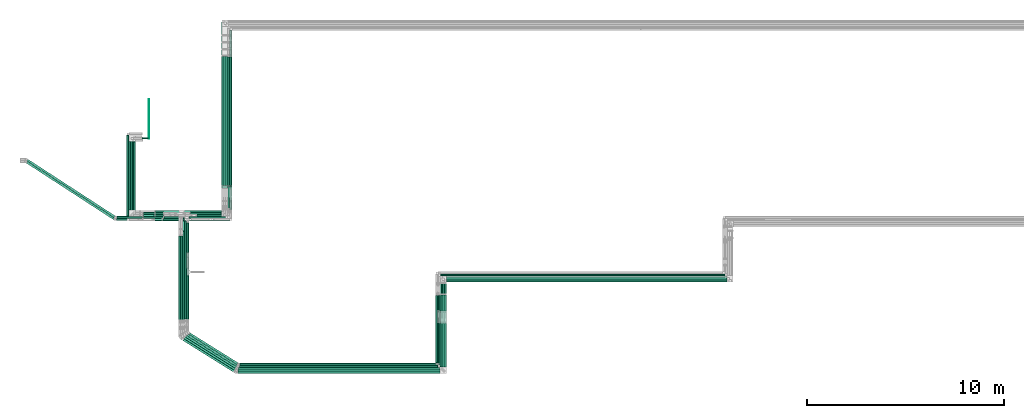
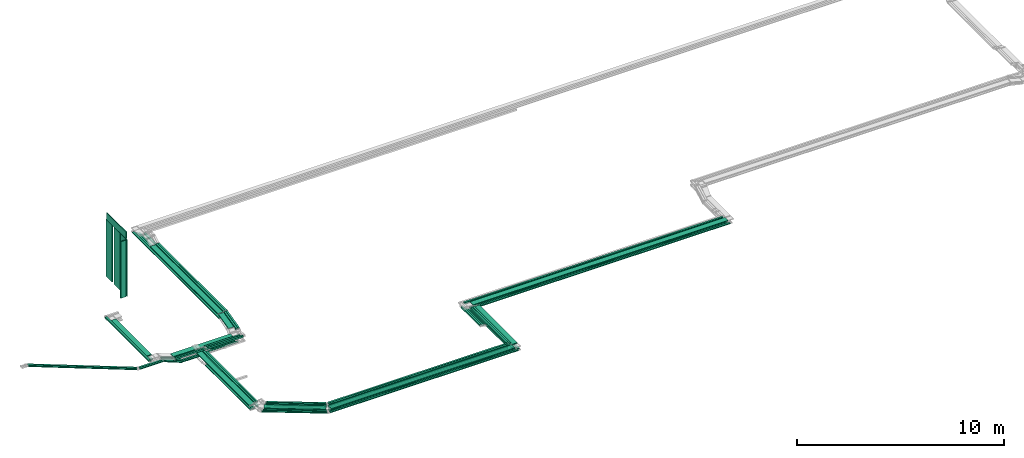
# One storey, part 1 of 14: 73 flow segments.
"""IFC2X3 building model written with IfcOpenShell, lengths in millimetres."""

from ifc_helpers import new_model, entity, si_unit, converted_unit, derived_unit, direction, frame, frame_2d, origin, origin_2d_with_axis, place, context, subcontext, project, spatial, rectangle, extrude, type_object, element, save


model = new_model("IFC2X3")

# Units and contexts
model_context = context("Model", 3, precision=0.01, world=origin(), true_north=direction((6.12303176911189e-17, 1.0)))
body_context = subcontext(model_context, "Body", "Model", "MODEL_VIEW")
ifc_project = project(units=[si_unit("LENGTHUNIT", "METRE", prefix="MILLI"), si_unit("AREAUNIT", "SQUARE_METRE"), si_unit("VOLUMEUNIT", "CUBIC_METRE"), converted_unit("PLANEANGLEUNIT", "DEGREE", entity("IfcRatioMeasure", 0.0174532925199433), si_unit("PLANEANGLEUNIT", "RADIAN"), dimensions=[0, 0, 0, 0, 0, 0, 0]), si_unit("MASSUNIT", "GRAM", prefix="KILO"), derived_unit("MASSDENSITYUNIT", [(si_unit("MASSUNIT", "GRAM", prefix="KILO"), 1), (si_unit("LENGTHUNIT", "METRE"), -3)]), derived_unit("MOMENTOFINERTIAUNIT", [(si_unit("LENGTHUNIT", "METRE"), 4)]), si_unit("TIMEUNIT", "SECOND"), si_unit("FREQUENCYUNIT", "HERTZ"), si_unit("THERMODYNAMICTEMPERATUREUNIT", "DEGREE_CELSIUS"), derived_unit("THERMALTRANSMITTANCEUNIT", [(si_unit("MASSUNIT", "GRAM", prefix="KILO"), 1), (si_unit("THERMODYNAMICTEMPERATUREUNIT", "KELVIN"), -1), (si_unit("TIMEUNIT", "SECOND"), -3)]), derived_unit("VOLUMETRICFLOWRATEUNIT", [(si_unit("LENGTHUNIT", "METRE"), 3), (si_unit("TIMEUNIT", "SECOND"), -1)]), derived_unit("MASSFLOWRATEUNIT", [(si_unit("MASSUNIT", "GRAM", prefix="KILO"), 1), (si_unit("TIMEUNIT", "SECOND"), -1)]), derived_unit("ROTATIONALFREQUENCYUNIT", [(si_unit("TIMEUNIT", "SECOND"), -1)]), si_unit("ELECTRICCURRENTUNIT", "AMPERE"), si_unit("ELECTRICVOLTAGEUNIT", "VOLT"), si_unit("POWERUNIT", "WATT"), si_unit("FORCEUNIT", "NEWTON", prefix="KILO"), si_unit("ILLUMINANCEUNIT", "LUX"), si_unit("LUMINOUSFLUXUNIT", "LUMEN"), si_unit("LUMINOUSINTENSITYUNIT", "CANDELA"), derived_unit("USERDEFINED", [(si_unit("MASSUNIT", "GRAM", prefix="KILO"), -1), (si_unit("LENGTHUNIT", "METRE"), -2), (si_unit("TIMEUNIT", "SECOND"), 3), (si_unit("LUMINOUSFLUXUNIT", "LUMEN"), 1)]), derived_unit("LINEARVELOCITYUNIT", [(si_unit("LENGTHUNIT", "METRE"), 1), (si_unit("TIMEUNIT", "SECOND"), -1)]), si_unit("PRESSUREUNIT", "PASCAL"), derived_unit("USERDEFINED", [(si_unit("LENGTHUNIT", "METRE"), -2), (si_unit("MASSUNIT", "GRAM", prefix="KILO"), 1), (si_unit("TIMEUNIT", "SECOND"), -2)]), derived_unit("LINEARFORCEUNIT", [(si_unit("MASSUNIT", "GRAM", prefix="KILO"), 1), (si_unit("LENGTHUNIT", "METRE"), 1), (si_unit("TIMEUNIT", "SECOND"), -2), (si_unit("LENGTHUNIT", "METRE"), -1)]), derived_unit("PLANARFORCEUNIT", [(si_unit("MASSUNIT", "GRAM", prefix="KILO"), 1), (si_unit("LENGTHUNIT", "METRE"), 1), (si_unit("TIMEUNIT", "SECOND"), -2), (si_unit("LENGTHUNIT", "METRE"), -2)])], contexts=[model_context])

# Site, building, storey
site_placement = place(None, origin())
site = spatial("IfcSite", under=ifc_project, at=site_placement, CompositionType="ELEMENT")
building_placement = place(site_placement, origin())
building = spatial("IfcBuilding", under=site, at=building_placement, CompositionType="ELEMENT")
storey_placement = place(building_placement, frame((0.0, 0.0, 19800.0)))
storey = spatial("IfcBuildingStorey", under=building, at=storey_placement, CompositionType="ELEMENT", Elevation=19800.0)

# Flow segments
cable_carrier_segment_type_1 = type_object("IfcCableCarrierSegmentType", PredefinedType="CABLETRAYSEGMENT")
flow_segment_1_placement = place(storey_placement, frame((20190.22, 11603.0, 3300.0)))
element("IfcFlowSegment", 1, at=flow_segment_1_placement, inside=storey, type_object=cable_carrier_segment_type_1, context=body_context, shape_type="SweptSolid", body=[
    extrude(rectangle(XDim=6551.54787533766, YDim=300.000000000001, at=origin_2d_with_axis()), frame((150.0, 3275.77, 0.0), z_axis=(0.0, 0.0, 1.0), x_axis=(0.0, 1.0, 0.0)), (0.0, 0.0, 1.0), 49.9999999999973),
])
flow_segment_2_placement = place(storey_placement, frame((20495.22, 11609.12, 3300.0)))
element("IfcFlowSegment", 2, at=flow_segment_2_placement, inside=storey, type_object=cable_carrier_segment_type_1, context=body_context, shape_type="SweptSolid", body=[
    extrude(rectangle(XDim=6531.55992167095, YDim=100.000000000003, at=origin_2d_with_axis()), frame((50.0, 3265.78, 0.0), z_axis=(0.0, 0.0, 1.0), x_axis=(0.0, 1.0, 0.0)), (0.0, 0.0, 1.0), 100.000000000003),
])
flow_segment_3_placement = place(storey_placement, frame((20600.22, 11501.25, 3100.0)))
element("IfcFlowSegment", 3, at=flow_segment_3_placement, inside=storey, type_object=cable_carrier_segment_type_1, context=body_context, shape_type="SweptSolid", body=[
    extrude(rectangle(XDim=7968.74949015567, YDim=100.000000000003, at=origin_2d_with_axis()), frame((50.0, 3984.37, 0.0), z_axis=(0.0, 0.0, 1.0), x_axis=(0.0, -1.0, 0.0)), (0.0, 0.0, 1.0), 100.000000000003),
])
flow_segment_4_placement = place(storey_placement, frame((20190.22, 11493.51, 3100.0)))
element("IfcFlowSegment", 4, at=flow_segment_4_placement, inside=storey, type_object=cable_carrier_segment_type_1, context=body_context, shape_type="SweptSolid", body=[
    extrude(rectangle(XDim=8386.48782817678, YDim=100.000000000003, at=origin_2d_with_axis()), frame((50.0, 4193.24, 0.0), z_axis=(0.0, 0.0, 1.0), x_axis=(0.0, -1.0, 0.0)), (0.0, 0.0, 1.0), 49.9999999999973),
])
flow_segment_5_placement = place(storey_placement, frame((20295.22, 11493.51, 3100.0)))
element("IfcFlowSegment", 5, at=flow_segment_5_placement, inside=storey, type_object=cable_carrier_segment_type_1, context=body_context, shape_type="SweptSolid", body=[
    extrude(rectangle(XDim=8281.48782817677, YDim=100.000000000003, at=origin_2d_with_axis()), frame((50.0, 4140.74, 0.0), z_axis=(0.0, 0.0, 1.0), x_axis=(0.0, -1.0, 0.0)), (0.0, 0.0, 1.0), 49.9999999999973),
])
flow_segment_6_placement = place(storey_placement, frame((20400.22, 11493.51, 3100.0)))
element("IfcFlowSegment", 6, at=flow_segment_6_placement, inside=storey, type_object=cable_carrier_segment_type_1, context=body_context, shape_type="SweptSolid", body=[
    extrude(rectangle(XDim=8176.48782817679, YDim=100.000000000003, at=origin_2d_with_axis()), frame((50.0, 4088.24, 0.0), z_axis=(0.0, 0.0, 1.0), x_axis=(0.0, -1.0, 0.0)), (0.0, 0.0, 1.0), 49.9999999999973),
])
flow_segment_7_placement = place(storey_placement, frame((18157.54, 10050.13, 2900.0)))
element("IfcFlowSegment", 7, at=flow_segment_7_placement, inside=storey, type_object=cable_carrier_segment_type_1, context=body_context, shape_type="SweptSolid", body=[
    extrude(rectangle(XDim=2012.67275358651, YDim=300.000000000001, at=origin_2d_with_axis()), frame((1006.34, 150.0, 0.0), z_axis=(0.0, 0.0, 1.0), x_axis=(-1.0, 0.0, 0.0)), (0.0, 0.0, 1.0), 49.9999999999973),
])
flow_segment_8_placement = place(storey_placement, frame((18522.14, 9944.24, 2900.0)))
element("IfcFlowSegment", 8, at=flow_segment_8_placement, inside=storey, type_object=cable_carrier_segment_type_1, context=body_context, shape_type="SweptSolid", body=[
    extrude(rectangle(XDim=1953.07275358647, YDim=99.9999999999989, at=origin_2d_with_axis()), frame((976.54, 50.0, 0.0), z_axis=(0.0, 0.0, 1.0), x_axis=(-1.0, 0.0, 0.0)), (0.0, 0.0, 1.0), 100.000000000003),
])
flow_segment_9_placement = place(storey_placement, frame((16789.0, 9824.22, 2900.0)))
element("IfcFlowSegment", 9, at=flow_segment_9_placement, inside=storey, type_object=cable_carrier_segment_type_1, context=body_context, shape_type="SweptSolid", body=[
    extrude(rectangle(XDim=1677.74327889368, YDim=99.9999999999989, at=origin_2d_with_axis()), frame((838.87, 50.0, 0.0)), (0.0, 0.0, 1.0), 100.000000000003),
])
flow_segment_10_placement = place(storey_placement, frame((17191.35, 9840.23, 2600.0)))
element("IfcFlowSegment", 10, at=flow_segment_10_placement, inside=storey, type_object=cable_carrier_segment_type_1, context=body_context, shape_type="SweptSolid", body=[
    extrude(rectangle(XDim=1095.79181857732, YDim=99.9999999999989, at=origin_2d_with_axis()), frame((547.9, 50.0, 0.0)), (0.0, 0.0, 1.0), 49.9999999999973),
])
flow_segment_11_placement = place(storey_placement, frame((17256.59, 9944.24, 2600.0)))
element("IfcFlowSegment", 11, at=flow_segment_11_placement, inside=storey, type_object=cable_carrier_segment_type_1, context=body_context, shape_type="SweptSolid", body=[
    extrude(rectangle(XDim=3123.62777329295, YDim=99.9999999999989, at=origin_2d_with_axis()), frame((1561.81, 50.0, 0.0), z_axis=(0.0, 0.0, 1.0), x_axis=(-1.0, 0.0, 0.0)), (0.0, 0.0, 1.0), 50.0000000000016),
])
flow_segment_12_placement = place(storey_placement, frame((31591.43, 6717.78, 2800.0)))
element("IfcFlowSegment", 12, at=flow_segment_12_placement, inside=storey, type_object=cable_carrier_segment_type_1, context=body_context, shape_type="SweptSolid", body=[
    extrude(rectangle(XDim=14204.952720189, YDim=300.000000000001, at=origin_2d_with_axis()), frame((7102.48, 150.0, 0.0), z_axis=(0.0, 0.0, 1.0), x_axis=(-1.0, 0.0, 0.0)), (0.0, 0.0, 1.0), 49.9999999999973),
])
flow_segment_13_placement = place(storey_placement, frame((31280.61, 7021.93, 2800.0)))
element("IfcFlowSegment", 13, at=flow_segment_13_placement, inside=storey, type_object=cable_carrier_segment_type_1, context=body_context, shape_type="SweptSolid", body=[
    extrude(rectangle(XDim=14408.678815753, YDim=100.000000000001, at=origin_2d_with_axis()), frame((7204.34, 50.0, 0.0), z_axis=(0.0, 0.0, 1.0), x_axis=(-1.0, 0.0, 0.0)), (0.0, 0.0, 1.0), 100.000000000003),
])
flow_segment_14_placement = place(storey_placement, frame((31591.43, 6717.78, 2600.0)))
element("IfcFlowSegment", 14, at=flow_segment_14_placement, inside=storey, type_object=cable_carrier_segment_type_1, context=body_context, shape_type="SweptSolid", body=[
    extrude(rectangle(XDim=14323.3274230858, YDim=99.9999999999989, at=origin_2d_with_axis()), frame((7161.66, 50.0, 0.0), z_axis=(0.0, 0.0, 1.0), x_axis=(-1.0, 0.0, 0.0)), (0.0, 0.0, 1.0), 50.0000000000016),
])
flow_segment_15_placement = place(storey_placement, frame((31481.5, 6822.78, 2600.0)))
element("IfcFlowSegment", 15, at=flow_segment_15_placement, inside=storey, type_object=cable_carrier_segment_type_1, context=body_context, shape_type="SweptSolid", body=[
    extrude(rectangle(XDim=14320.0, YDim=99.9999999999989, at=origin_2d_with_axis()), frame((7160.0, 50.0, 0.0), z_axis=(0.0, 0.0, 1.0), x_axis=(-1.0, 0.0, 0.0)), (0.0, 0.0, 1.0), 49.9999999999973),
])
flow_segment_16_placement = place(storey_placement, frame((21062.59, 2392.27, 3200.0)))
element("IfcFlowSegment", 16, at=flow_segment_16_placement, inside=storey, type_object=cable_carrier_segment_type_1, context=body_context, shape_type="SweptSolid", body=[
    extrude(rectangle(XDim=10078.0137037583, YDim=100.0, at=origin_2d_with_axis()), frame((5039.01, 50.0, 0.0), z_axis=(0.0, 0.0, 1.0), x_axis=(-1.0, 0.0, 0.0)), (0.0, 0.0, 1.0), 100.000000000008),
])
flow_segment_17_placement = place(storey_placement, frame((20986.65, 2192.27, 3000.0)))
element("IfcFlowSegment", 17, at=flow_segment_17_placement, inside=storey, type_object=cable_carrier_segment_type_1, context=body_context, shape_type="SweptSolid", body=[
    extrude(rectangle(XDim=10354.846485042, YDim=100.0, at=origin_2d_with_axis()), frame((5177.42, 50.0, 0.0), z_axis=(0.0, 0.0, 1.0), x_axis=(-1.0, 0.0, 0.0)), (0.0, 0.0, 1.0), 49.9999999999973),
])
flow_segment_18_placement = place(storey_placement, frame((18007.14, 4795.41, 2800.0)))
element("IfcFlowSegment", 18, at=flow_segment_18_placement, inside=storey, type_object=cable_carrier_segment_type_1, context=body_context, shape_type="SweptSolid", body=[
    extrude(rectangle(XDim=5199.72119742787, YDim=300.000000000001, at=origin_2d_with_axis()), frame((150.0, 2599.86, 0.0), z_axis=(0.0, 0.0, 1.0), x_axis=(0.0, 1.0, 0.0)), (0.0, 0.0, 1.0), 49.9999999999973),
])
flow_segment_19_placement = place(storey_placement, frame((18312.14, 4839.93, 2800.0)))
element("IfcFlowSegment", 19, at=flow_segment_19_placement, inside=storey, type_object=cable_carrier_segment_type_1, context=body_context, shape_type="SweptSolid", body=[
    extrude(rectangle(XDim=5127.14874316907, YDim=99.9999999999989, at=origin_2d_with_axis()), frame((50.0, 2563.57, 0.0), z_axis=(0.0, 0.0, 1.0), x_axis=(0.0, 1.0, 0.0)), (0.0, 0.0, 1.0), 100.000000000003),
])
flow_segment_20_placement = place(storey_placement, frame((18417.14, 8193.95, 2600.0)))
element("IfcFlowSegment", 20, at=flow_segment_20_placement, inside=storey, type_object=cable_carrier_segment_type_1, context=body_context, shape_type="SweptSolid", body=[
    extrude(rectangle(XDim=1516.27528069827, YDim=99.9999999999989, at=origin_2d_with_axis()), frame((50.0, 758.14, 0.0), z_axis=(0.0, 0.0, 1.0), x_axis=(0.0, -1.0, 0.0)), (0.0, 0.0, 1.0), 50.0000000000016),
])
flow_segment_21_placement = place(storey_placement, frame((18007.14, 4732.08, 2600.0)))
element("IfcFlowSegment", 21, at=flow_segment_21_placement, inside=storey, type_object=cable_carrier_segment_type_1, context=body_context, shape_type="SweptSolid", body=[
    extrude(rectangle(XDim=4319.69591813559, YDim=99.9999999999989, at=origin_2d_with_axis()), frame((50.0, 2159.85, 0.0), z_axis=(0.0, 0.0, 1.0), x_axis=(0.0, 1.0, 0.0)), (0.0, 0.0, 1.0), 49.9999999999973),
])
flow_segment_22_placement = place(storey_placement, frame((18112.14, 4732.08, 2600.0)))
element("IfcFlowSegment", 22, at=flow_segment_22_placement, inside=storey, type_object=cable_carrier_segment_type_1, context=body_context, shape_type="SweptSolid", body=[
    extrude(rectangle(XDim=4319.6959181356, YDim=99.9999999999989, at=origin_2d_with_axis()), frame((50.0, 2159.85, 0.0), z_axis=(0.0, 0.0, 1.0), x_axis=(0.0, 1.0, 0.0)), (0.0, 0.0, 1.0), 49.9999999999973),
])
flow_segment_23_placement = place(storey_placement, frame((18217.14, 4732.08, 2600.0)))
element("IfcFlowSegment", 23, at=flow_segment_23_placement, inside=storey, type_object=cable_carrier_segment_type_1, context=body_context, shape_type="SweptSolid", body=[
    extrude(rectangle(XDim=4546.36734918782, YDim=99.9999999999989, at=origin_2d_with_axis()), frame((50.0, 2273.18, 0.0), z_axis=(0.0, 0.0, 1.0), x_axis=(0.0, 1.0, 0.0)), (0.0, 0.0, 1.0), 49.9999999999973),
])
flow_segment_24_placement = place(storey_placement, frame((31125.11, 2617.27, 3000.0)))
element("IfcFlowSegment", 24, at=flow_segment_24_placement, inside=storey, type_object=cable_carrier_segment_type_1, context=body_context, shape_type="SweptSolid", body=[
    extrude(rectangle(XDim=2031.89362716771, YDim=100.000000000003, at=origin_2d_with_axis()), frame((50.0, 1015.95, 0.0), z_axis=(0.0, 0.0, 1.0), x_axis=(0.0, 1.0, 0.0)), (0.0, 0.0, 1.0), 99.9999999999989),
])
flow_segment_25_placement = place(storey_placement, frame((31125.11, 5296.63, 2600.0)))
element("IfcFlowSegment", 25, at=flow_segment_25_placement, inside=storey, type_object=cable_carrier_segment_type_1, context=body_context, shape_type="SweptSolid", body=[
    extrude(rectangle(XDim=1808.36637507826, YDim=100.000000000003, at=origin_2d_with_axis()), frame((50.0, 904.18, 0.0), z_axis=(0.0, 0.0, 1.0), x_axis=(0.0, 1.0, 0.0)), (0.0, 0.0, 1.0), 100.000000000003),
])
flow_segment_26_placement = place(storey_placement, frame((31249.29, 5245.16, 2600.0)))
element("IfcFlowSegment", 26, at=flow_segment_26_placement, inside=storey, type_object=cable_carrier_segment_type_1, context=body_context, shape_type="SweptSolid", body=[
    extrude(rectangle(XDim=1662.61404192942, YDim=100.000000000003, at=origin_2d_with_axis()), frame((50.0, 831.31, 0.0), z_axis=(0.0, 0.0, 1.0), x_axis=(0.0, -1.0, 0.0)), (0.0, 0.0, 1.0), 49.9999999999973),
])
flow_segment_27_placement = place(storey_placement, frame((31249.29, 2417.27, 3000.0)))
element("IfcFlowSegment", 27, at=flow_segment_27_placement, inside=storey, type_object=cable_carrier_segment_type_1, context=body_context, shape_type="SweptSolid", body=[
    extrude(rectangle(XDim=2211.95486644315, YDim=100.000000000003, at=origin_2d_with_axis()), frame((50.0, 1105.98, 0.0), z_axis=(0.0, 0.0, 1.0), x_axis=(0.0, 1.0, 0.0)), (0.0, 0.0, 1.0), 49.9999999999973),
])
flow_segment_28_placement = place(storey_placement, frame((31361.5, 5245.16, 2600.0)))
element("IfcFlowSegment", 28, at=flow_segment_28_placement, inside=storey, type_object=cable_carrier_segment_type_1, context=body_context, shape_type="SweptSolid", body=[
    extrude(rectangle(XDim=1557.61404192941, YDim=100.000000000003, at=origin_2d_with_axis()), frame((50.0, 778.81, 0.0), z_axis=(0.0, 0.0, 1.0), x_axis=(0.0, -1.0, 0.0)), (0.0, 0.0, 1.0), 49.9999999999973),
])
flow_segment_29_placement = place(storey_placement, frame((31361.5, 2312.27, 3000.0)))
element("IfcFlowSegment", 29, at=flow_segment_29_placement, inside=storey, type_object=cable_carrier_segment_type_1, context=body_context, shape_type="SweptSolid", body=[
    extrude(rectangle(XDim=2316.95486644316, YDim=100.000000000003, at=origin_2d_with_axis()), frame((50.0, 1158.48, 0.0), z_axis=(0.0, 0.0, 1.0), x_axis=(0.0, -1.0, 0.0)), (0.0, 0.0, 1.0), 49.9999999999973),
])
flow_segment_30_placement = place(storey_placement, frame((31471.43, 5245.16, 2600.0)))
element("IfcFlowSegment", 30, at=flow_segment_30_placement, inside=storey, type_object=cable_carrier_segment_type_1, context=body_context, shape_type="SweptSolid", body=[
    extrude(rectangle(XDim=1452.61404192941, YDim=100.000000000003, at=origin_2d_with_axis()), frame((50.0, 726.31, 0.0), z_axis=(0.0, 0.0, 1.0), x_axis=(0.0, -1.0, 0.0)), (0.0, 0.0, 1.0), 49.9999999999973),
])
flow_segment_31_placement = place(storey_placement, frame((31471.43, 2207.27, 3000.0)))
element("IfcFlowSegment", 31, at=flow_segment_31_placement, inside=storey, type_object=cable_carrier_segment_type_1, context=body_context, shape_type="SweptSolid", body=[
    extrude(rectangle(XDim=2421.95486644317, YDim=100.000000000003, at=origin_2d_with_axis()), frame((50.0, 1210.98, 0.0), z_axis=(0.0, 0.0, 1.0), x_axis=(0.0, 1.0, 0.0)), (0.0, 0.0, 1.0), 49.9999999999973),
])
flow_segment_32_placement = place(storey_placement, frame((31271.43, 2407.27, 3200.0)))
element("IfcFlowSegment", 32, at=flow_segment_32_placement, inside=storey, type_object=cable_carrier_segment_type_1, context=body_context, shape_type="SweptSolid", body=[
    extrude(rectangle(XDim=3662.65856661165, YDim=300.000000000001, at=origin_2d_with_axis()), frame((150.0, 1831.33, 0.0), z_axis=(0.0, 0.0, 1.0), x_axis=(0.0, 1.0, 0.0)), (0.0, 0.0, 1.0), 49.9999999999973),
])
flow_segment_33_placement = place(storey_placement, frame((31160.61, 2512.27, 3200.0)))
element("IfcFlowSegment", 33, at=flow_segment_33_placement, inside=storey, type_object=cable_carrier_segment_type_1, context=body_context, shape_type="SweptSolid", body=[
    extrude(rectangle(XDim=3526.8936271677, YDim=100.000000000003, at=origin_2d_with_axis()), frame((50.0, 1763.45, 0.0), z_axis=(0.0, 0.0, 1.0), x_axis=(0.0, 1.0, 0.0)), (0.0, 0.0, 1.0), 100.000000000003),
])
flow_segment_34_placement = place(storey_placement, frame((31047.89, 2620.0, 3200.0)))
element("IfcFlowSegment", 34, at=flow_segment_34_placement, inside=storey, type_object=cable_carrier_segment_type_1, context=body_context, shape_type="SweptSolid", body=[
    extrude(rectangle(XDim=3419.24047842777, YDim=100.000000000003, at=origin_2d_with_axis()), frame((50.0, 1709.62, 0.0), z_axis=(0.0, 0.0, 1.0), x_axis=(0.0, 1.0, 0.0)), (0.0, 0.0, 1.0), 100.000000000008),
])
flow_segment_35_placement = place(storey_placement, frame((21097.29, 2497.27, 3000.0)))
element("IfcFlowSegment", 35, at=flow_segment_35_placement, inside=storey, type_object=cable_carrier_segment_type_1, context=body_context, shape_type="SweptSolid", body=[
    extrude(rectangle(XDim=10007.8208838715, YDim=100.0, at=origin_2d_with_axis()), frame((5003.91, 50.0, 0.0), z_axis=(0.0, 0.0, 1.0), x_axis=(-1.0, 0.0, 0.0)), (0.0, 0.0, 1.0), 100.000000000003),
])
flow_segment_36_placement = place(storey_placement, frame((18430.51, 2430.79, 3200.0)))
element("IfcFlowSegment", 36, at=flow_segment_36_placement, inside=storey, type_object=cable_carrier_segment_type_1, context=body_context, shape_type="SweptSolid", body=[
    extrude(rectangle(XDim=2945.29672939392, YDim=100.000000000004, at=origin_2d_with_axis()), frame((1275.37, 822.79, 0.0), z_axis=(0.0, 0.0, 1.0), x_axis=(-0.848048096156423, 0.52991926423321, 0.0)), (0.0, 0.0, 1.0), 100.000000000003),
])
flow_segment_37_placement = place(storey_placement, frame((21014.25, 2297.27, 3000.0)))
element("IfcFlowSegment", 37, at=flow_segment_37_placement, inside=storey, type_object=cable_carrier_segment_type_1, context=body_context, shape_type="SweptSolid", body=[
    extrude(rectangle(XDim=10215.0397317824, YDim=100.0, at=origin_2d_with_axis()), frame((5107.52, 50.0, 0.0), z_axis=(0.0, 0.0, 1.0), x_axis=(-1.0, 0.0, 0.0)), (0.0, 0.0, 1.0), 49.9999999999973),
])
flow_segment_38_placement = place(storey_placement, frame((20950.04, 2087.27, 3000.0)))
element("IfcFlowSegment", 38, at=flow_segment_38_placement, inside=storey, type_object=cable_carrier_segment_type_1, context=body_context, shape_type="SweptSolid", body=[
    extrude(rectangle(XDim=10501.3978164659, YDim=100.0, at=origin_2d_with_axis()), frame((5250.7, 50.0, 0.0), z_axis=(0.0, 0.0, 1.0), x_axis=(-1.0, 0.0, 0.0)), (0.0, 0.0, 1.0), 49.9999999999973),
])
flow_segment_39_placement = place(storey_placement, frame((18125.51, 2125.79, 3000.0)))
element("IfcFlowSegment", 39, at=flow_segment_39_placement, inside=storey, type_object=cable_carrier_segment_type_1, context=body_context, shape_type="SweptSolid", body=[
    extrude(rectangle(XDim=3172.2205568259, YDim=100.000000000005, at=origin_2d_with_axis()), frame((1371.59, 882.91, 0.0), z_axis=(0.0, 0.0, 1.0), x_axis=(-0.848048096156423, 0.52991926423321, 0.0)), (0.0, 0.0, 1.0), 49.9999999999973),
])
flow_segment_40_placement = place(storey_placement, frame((21002.32, 2087.27, 3200.0)))
element("IfcFlowSegment", 40, at=flow_segment_40_placement, inside=storey, type_object=cable_carrier_segment_type_1, context=body_context, shape_type="SweptSolid", body=[
    extrude(rectangle(XDim=10249.1129852784, YDim=300.0, at=origin_2d_with_axis()), frame((5124.56, 150.0, 0.0), z_axis=(0.0, 0.0, 1.0), x_axis=(-1.0, 0.0, 0.0)), (0.0, 0.0, 1.0), 49.9999999999973),
])
flow_segment_41_placement = place(storey_placement, frame((21092.92, 2500.0, 3200.0)))
element("IfcFlowSegment", 41, at=flow_segment_41_placement, inside=storey, type_object=cable_carrier_segment_type_1, context=body_context, shape_type="SweptSolid", body=[
    extrude(rectangle(XDim=9934.97609200436, YDim=100.0, at=origin_2d_with_axis()), frame((4967.49, 50.0, 0.0), z_axis=(0.0, 0.0, 1.0), x_axis=(-1.0, 0.0, 0.0)), (0.0, 0.0, 1.0), 100.000000000008),
])
flow_segment_42_placement = place(storey_placement, frame((18535.51, 2538.52, 3200.0)))
element("IfcFlowSegment", 42, at=flow_segment_42_placement, inside=storey, type_object=cable_carrier_segment_type_1, context=body_context, shape_type="SweptSolid", body=[
    extrude(rectangle(XDim=2857.23886438621, YDim=100.000000000005, at=origin_2d_with_axis()), frame((1238.03, 799.46, 0.0), z_axis=(0.0, 0.0, 1.0), x_axis=(-0.84804809615642, 0.529919264233215, 0.0)), (0.0, 0.0, 1.0), 100.000000000003),
])
flow_segment_43_placement = place(storey_placement, frame((18230.51, 2230.79, 3000.0)))
element("IfcFlowSegment", 43, at=flow_segment_43_placement, inside=storey, type_object=cable_carrier_segment_type_1, context=body_context, shape_type="SweptSolid", body=[
    extrude(rectangle(XDim=3091.5847138092, YDim=100.000000000005, at=origin_2d_with_axis()), frame((1337.4, 861.55, 0.0), z_axis=(0.0, 0.0, 1.0), x_axis=(-0.848048096156424, 0.529919264233208, 0.0)), (0.0, 0.0, 1.0), 49.9999999999973),
])
flow_segment_44_placement = place(storey_placement, frame((18335.51, 2335.79, 3000.0)))
element("IfcFlowSegment", 44, at=flow_segment_44_placement, inside=storey, type_object=cable_carrier_segment_type_1, context=body_context, shape_type="SweptSolid", body=[
    extrude(rectangle(XDim=3000.30868914057, YDim=100.000000000005, at=origin_2d_with_axis()), frame((1298.7, 837.36, 0.0), z_axis=(0.0, 0.0, 1.0), x_axis=(-0.848048096156424, 0.529919264233208, 0.0)), (0.0, 0.0, 1.0), 49.9999999999973),
])
flow_segment_45_placement = place(storey_placement, frame((18535.51, 2535.79, 3000.0)))
element("IfcFlowSegment", 45, at=flow_segment_45_placement, inside=storey, type_object=cable_carrier_segment_type_1, context=body_context, shape_type="SweptSolid", body=[
    extrude(rectangle(XDim=2862.39408159168, YDim=99.9999999999956, at=origin_2d_with_axis()), frame((1240.22, 800.82, 0.0), z_axis=(0.0, 0.0, 1.0), x_axis=(-0.848048096156425, 0.529919264233207, 0.0)), (0.0, 0.0, 1.0), 100.000000000003),
])
flow_segment_46_placement = place(storey_placement, frame((18219.53, 2156.18, 3200.0)))
element("IfcFlowSegment", 46, at=flow_segment_46_placement, inside=storey, type_object=cable_carrier_segment_type_1, context=body_context, shape_type="SweptSolid", body=[
    extrude(rectangle(XDim=2998.03801991332, YDim=300.000000000004, at=origin_2d_with_axis()), frame((1350.73, 921.57, 0.0), z_axis=(0.0, 0.0, 1.0), x_axis=(-0.848048096156424, 0.529919264233208, 0.0)), (0.0, 0.0, 1.0), 49.9999999999973),
])
flow_segment_47_placement = place(storey_placement, frame((20600.22, 11609.12, 3300.0)))
element("IfcFlowSegment", 47, at=flow_segment_47_placement, inside=storey, type_object=cable_carrier_segment_type_1, context=body_context, shape_type="SweptSolid", body=[
    extrude(rectangle(XDim=6531.55992167089, YDim=100.000000000003, at=origin_2d_with_axis()), frame((50.0, 3265.78, 0.0), z_axis=(0.0, 0.0, 1.0), x_axis=(0.0, 1.0, 0.0)), (0.0, 0.0, 1.0), 100.000000000003),
])
flow_segment_48_placement = place(storey_placement, frame((20600.22, 10390.08, 3005.86)))
element("IfcFlowSegment", 48, at=flow_segment_48_placement, inside=storey, type_object=cable_carrier_segment_type_1, context=body_context, shape_type="SweptSolid", body=[
    extrude(rectangle(XDim=99.9999999999975, YDim=1207.4663906893, at=frame_2d((0.0, 0.0), x_axis=(0.0, 1.0))), frame((0.0, 597.96, 194.18), z_axis=(1.0, 0.0, 0.0), x_axis=(0.0, 0.970462347809245, 0.241252630005495)), (0.0, 0.0, 1.0), 100.000000000003),
])
flow_segment_49_placement = place(storey_placement, frame((20495.22, 10390.08, 3005.86)))
element("IfcFlowSegment", 49, at=flow_segment_49_placement, inside=storey, type_object=cable_carrier_segment_type_1, context=body_context, shape_type="SweptSolid", body=[
    extrude(rectangle(XDim=99.999999999998, YDim=1207.46639068923, at=frame_2d((0.0, 0.0), x_axis=(0.0, 1.0))), frame((0.0, 597.96, 194.18), z_axis=(1.0, 0.0, 0.0), x_axis=(0.0, -0.970462347809245, -0.241252630005494)), (0.0, 0.0, 1.0), 99.9999999999989),
])
flow_segment_50_placement = place(storey_placement, frame((20190.22, 10586.87, 3052.55)))
element("IfcFlowSegment", 50, at=flow_segment_50_placement, inside=storey, type_object=cable_carrier_segment_type_1, context=body_context, shape_type="SweptSolid", body=[
    extrude(rectangle(XDim=50.0000000000032, YDim=1017.02134440409, at=frame_2d((0.0, 0.0), x_axis=(0.0, 1.0))), frame((0.0, 499.52, 146.94), z_axis=(1.0, 0.0, 0.0), x_axis=(0.0, -0.970462347809243, -0.241252630005501)), (0.0, 0.0, 1.0), 300.000000000001),
])
flow_segment_51_placement = place(storey_placement, frame((16196.74, 10152.84, 2607.02)))
element("IfcFlowSegment", 51, at=flow_segment_51_placement, inside=storey, type_object=cable_carrier_segment_type_1, context=body_context, shape_type="SweptSolid", body=[
    extrude(rectangle(XDim=49.9999999999978, YDim=99.9999999999989, at=origin_2d_with_axis()), frame((8.9, 50.0, 412.6), z_axis=(0.934483298097407, 0.0, -0.356006974056679), x_axis=(0.356006974056679, 0.0, 0.934483298097407)), (0.0, 0.0, 1.0), 1093.32996658713),
])
for number, where in (
    (52, (16196.74, 10049.82, 2607.02)),
    (53, (16196.74, 9944.24, 2607.02)),
):
    element("IfcFlowSegment", number, at=place(storey_placement, frame(where)), inside=storey, type_object=cable_carrier_segment_type_1, context=body_context, shape_type="SweptSolid", body=[
        extrude(rectangle(XDim=49.9999999999978, YDim=99.9999999999989, at=origin_2d_with_axis()), frame((8.9, 50.0, 412.6), z_axis=(0.934483298097407, 0.0, -0.356006974056679), x_axis=(0.356006974056679, 0.0, 0.934483298097407)), (0.0, 0.0, 1.0), 1093.32996658708),
    ])
flow_segment_52_placement = place(storey_placement, frame((14864.6, 9944.24, 3000.0)))
element("IfcFlowSegment", 54, at=flow_segment_52_placement, inside=storey, type_object=cable_carrier_segment_type_1, context=body_context, shape_type="SweptSolid", body=[
    extrude(rectangle(XDim=1311.78382857603, YDim=99.9999999999989, at=origin_2d_with_axis()), frame((655.89, 50.0, 0.0), z_axis=(0.0, 0.0, 1.0), x_axis=(-1.0, 0.0, 0.0)), (0.0, 0.0, 1.0), 49.9999999999973),
])
flow_segment_53_placement = place(storey_placement, frame((16163.82, 9840.23, 2607.48)))
element("IfcFlowSegment", 55, at=flow_segment_53_placement, inside=storey, type_object=cable_carrier_segment_type_1, context=body_context, shape_type="SweptSolid", body=[
    extrude(rectangle(XDim=49.9999999999963, YDim=99.9999999999989, at=origin_2d_with_axis()), frame((9.22, 50.0, 415.2), z_axis=(0.929573625278576, 0.0, -0.368636508211606), x_axis=(0.368636508211606, 0.0, 0.929573625278576)), (0.0, 0.0, 1.0), 1063.2806215525),
])
flow_segment_54_placement = place(storey_placement, frame((18467.54, 9824.22, 2900.0)))
element("IfcFlowSegment", 56, at=flow_segment_54_placement, inside=storey, type_object=cable_carrier_segment_type_1, context=body_context, shape_type="SweptSolid", body=[
    extrude(rectangle(XDim=2112.67275358652, YDim=99.9999999999989, at=origin_2d_with_axis()), frame((1056.34, 50.0, 0.0), z_axis=(0.0, 0.0, 1.0), x_axis=(-1.0, 0.0, 0.0)), (0.0, 0.0, 1.0), 100.000000000003),
])
flow_segment_55_placement = place(storey_placement, frame((18417.14, 4776.6, 2600.0)))
element("IfcFlowSegment", 57, at=flow_segment_55_placement, inside=storey, type_object=cable_carrier_segment_type_1, context=body_context, shape_type="SweptSolid", body=[
    extrude(rectangle(XDim=2267.1487431691, YDim=99.9999999999989, at=origin_2d_with_axis()), frame((50.0, 1133.57, 0.0), z_axis=(0.0, 0.0, 1.0), x_axis=(0.0, 1.0, 0.0)), (0.0, 0.0, 1.0), 100.000000000003),
])
flow_segment_56_placement = place(storey_placement, frame((18917.46, 10049.82, 2600.0)))
element("IfcFlowSegment", 58, at=flow_segment_56_placement, inside=storey, type_object=cable_carrier_segment_type_1, context=body_context, shape_type="SweptSolid", body=[
    extrude(rectangle(XDim=1357.75911263266, YDim=99.9999999999989, at=origin_2d_with_axis()), frame((678.88, 50.0, 0.0), z_axis=(0.0, 0.0, 1.0), x_axis=(-1.0, 0.0, 0.0)), (0.0, 0.0, 1.0), 49.9999999999973),
])
flow_segment_57_placement = place(storey_placement, frame((18587.97, 10152.84, 2600.0)))
element("IfcFlowSegment", 59, at=flow_segment_57_placement, inside=storey, type_object=cable_carrier_segment_type_1, context=body_context, shape_type="SweptSolid", body=[
    extrude(rectangle(XDim=1582.24295872755, YDim=99.9999999999989, at=origin_2d_with_axis()), frame((791.12, 50.0, 0.0), z_axis=(0.0, 0.0, 1.0), x_axis=(-1.0, 0.0, 0.0)), (0.0, 0.0, 1.0), 49.9999999999973),
])
flow_segment_58_placement = place(storey_placement, frame((16817.98, 10050.13, 2900.0)))
element("IfcFlowSegment", 60, at=flow_segment_58_placement, inside=storey, type_object=cable_carrier_segment_type_1, context=body_context, shape_type="SweptSolid", body=[
    extrude(rectangle(XDim=1338.76398992904, YDim=300.000000000001, at=origin_2d_with_axis()), frame((669.38, 150.0, 0.0)), (0.0, 0.0, 1.0), 50.0000000000016),
])
flow_segment_59_placement = place(storey_placement, frame((15490.0, 10370.13, 3200.0)))
element("IfcFlowSegment", 61, at=flow_segment_59_placement, inside=storey, type_object=cable_carrier_segment_type_1, context=body_context, shape_type="SweptSolid", body=[
    extrude(rectangle(XDim=3460.0, YDim=300.000000000001, at=origin_2d_with_axis()), frame((150.0, 1730.0, 0.0), z_axis=(0.0, 0.0, 1.0), x_axis=(0.0, 1.0, 0.0)), (0.0, 0.0, 1.0), 49.9999999999973),
])
flow_segment_60_placement = place(storey_placement, frame((15378.62, 9944.22, 3200.0)))
element("IfcFlowSegment", 62, at=flow_segment_60_placement, inside=storey, type_object=cable_carrier_segment_type_1, context=body_context, shape_type="SweptSolid", body=[
    extrude(rectangle(XDim=4216.00503583277, YDim=99.9999999999989, at=origin_2d_with_axis()), frame((50.0, 2108.0, 0.0), z_axis=(0.0, 0.0, 1.0), x_axis=(0.0, 1.0, 0.0)), (0.0, 0.0, 1.0), 100.000000000003),
])
flow_segment_61_placement = place(storey_placement, frame((15690.0, 10272.84, 3000.0)))
element("IfcFlowSegment", 63, at=flow_segment_61_placement, inside=storey, type_object=cable_carrier_segment_type_1, context=body_context, shape_type="SweptSolid", body=[
    extrude(rectangle(XDim=3557.28750820052, YDim=99.9999999999989, at=origin_2d_with_axis()), frame((50.0, 1778.64, 0.0), z_axis=(0.0, 0.0, 1.0), x_axis=(0.0, 1.0, 0.0)), (0.0, 0.0, 1.0), 49.9999999999973),
])
flow_segment_62_placement = place(storey_placement, frame((15581.77, 10169.82, 3000.0)))
element("IfcFlowSegment", 64, at=flow_segment_62_placement, inside=storey, type_object=cable_carrier_segment_type_1, context=body_context, shape_type="SweptSolid", body=[
    extrude(rectangle(XDim=3765.11562472394, YDim=99.9999999999989, at=origin_2d_with_axis()), frame((50.0, 1882.56, 0.0), z_axis=(0.0, 0.0, 1.0), x_axis=(0.0, 1.0, 0.0)), (0.0, 0.0, 1.0), 49.9999999999973),
])
flow_segment_63_placement = place(storey_placement, frame((10298.83, 9985.11, 3000.0)))
element("IfcFlowSegment", 65, at=flow_segment_63_placement, inside=storey, type_object=cable_carrier_segment_type_1, context=body_context, shape_type="SweptSolid", body=[
    extrude(rectangle(XDim=5279.51460201519, YDim=99.9999999999984, at=origin_2d_with_axis()), frame((2241.12, 1479.65, 0.0), z_axis=(0.0, 0.0, 1.0), x_axis=(-0.838670567945421, 0.544639035015032, 0.0)), (0.0, 0.0, 1.0), 49.9999999999973),
])
flow_segment_64_placement = place(storey_placement, frame((14826.45, 9840.23, 3003.4)))
element("IfcFlowSegment", 66, at=flow_segment_64_placement, inside=storey, type_object=cable_carrier_segment_type_1, context=body_context, shape_type="SweptSolid", body=[
    extrude(rectangle(XDim=1316.6631120587, YDim=99.9999999999989, at=origin_2d_with_axis()), frame((658.33, 50.0, 0.0), z_axis=(0.0, 0.0, 1.0), x_axis=(-1.0, 0.0, 0.0)), (0.0, 0.0, 1.0), 49.9999999999973),
])
flow_segment_65_placement = place(storey_placement, frame((10280.65, 9881.1, 3003.4)))
element("IfcFlowSegment", 67, at=flow_segment_65_placement, inside=storey, type_object=cable_carrier_segment_type_1, context=body_context, shape_type="SweptSolid", body=[
    extrude(rectangle(XDim=5255.69129290911, YDim=99.9999999999985, at=origin_2d_with_axis()), frame((2231.13, 1473.16, 0.0), z_axis=(0.0, 0.0, 1.0), x_axis=(-0.83867056794542, 0.544639035015034, 0.0)), (0.0, 0.0, 1.0), 49.9999999999973),
])
flow_segment_66_placement = place(storey_placement, frame((18417.14, 4839.93, 2800.0)))
element("IfcFlowSegment", 68, at=flow_segment_66_placement, inside=storey, type_object=cable_carrier_segment_type_1, context=body_context, shape_type="SweptSolid", body=[
    extrude(rectangle(XDim=4879.29374874634, YDim=99.9999999999989, at=origin_2d_with_axis()), frame((50.0, 2439.65, 0.0), z_axis=(0.0, 0.0, 1.0), x_axis=(0.0, 1.0, 0.0)), (0.0, 0.0, 1.0), 100.000000000003),
])
cable_carrier_segment_type_2 = type_object("IfcCableCarrierSegmentType", PredefinedType="CABLETRAYSEGMENT")
for number, where in (
    (69, (16472.31, 15387.61, 4225.84)),
    (70, (16472.31, 14607.61, 4225.84)),
):
    element("IfcFlowSegment", number, at=place(storey_placement, frame(where)), inside=storey, type_object=cable_carrier_segment_type_2, context=body_context, shape_type="SweptSolid", body=[
        extrude(rectangle(XDim=50.0000000000016, YDim=600.000000000002, at=origin_2d_with_axis()), frame((25.0, 300.0, 0.0), z_axis=(0.0, 0.0, 1.0), x_axis=(-1.0, 0.0, 0.0)), (0.0, 0.0, 1.0), 3339.15800428244),
    ])
flow_segment_67_placement = place(storey_placement, frame((16472.31, 13987.61, 4225.84)))
element("IfcFlowSegment", 71, at=flow_segment_67_placement, inside=storey, type_object=cable_carrier_segment_type_2, context=body_context, shape_type="SweptSolid", body=[
    extrude(rectangle(XDim=50.0000000000016, YDim=599.999999999998, at=origin_2d_with_axis()), frame((25.0, 300.0, 0.0), z_axis=(0.0, 0.0, 1.0), x_axis=(-1.0, 0.0, 0.0)), (0.0, 0.0, 1.0), 3340.0),
])
flow_segment_68_placement = place(storey_placement, frame((16147.31, 13982.61, 4225.84)))
element("IfcFlowSegment", 72, at=flow_segment_68_placement, inside=storey, type_object=cable_carrier_segment_type_2, context=body_context, shape_type="SweptSolid", body=[
    extrude(rectangle(XDim=50.0000000000016, YDim=300.000000000001, at=origin_2d_with_axis()), frame((150.0, 25.0, 0.0), z_axis=(0.0, 0.0, 1.0), x_axis=(0.0, 1.0, 0.0)), (0.0, 0.0, 1.0), 3340.0),
])
flow_segment_69_placement = place(storey_placement, frame((16472.31, 14051.24, 7584.26)))
element("IfcFlowSegment", 73, at=flow_segment_69_placement, inside=storey, type_object=cable_carrier_segment_type_2, context=body_context, shape_type="SweptSolid", body=[
    extrude(rectangle(XDim=1887.30000000508, YDim=50.0000000000016, at=origin_2d_with_axis()), frame((25.0, 943.65, 0.0), z_axis=(0.0, 0.0, 1.0), x_axis=(0.0, -1.0, 0.0)), (0.0, 0.0, 1.0), 400.000000000004),
])

save(model, "model.ifc")
